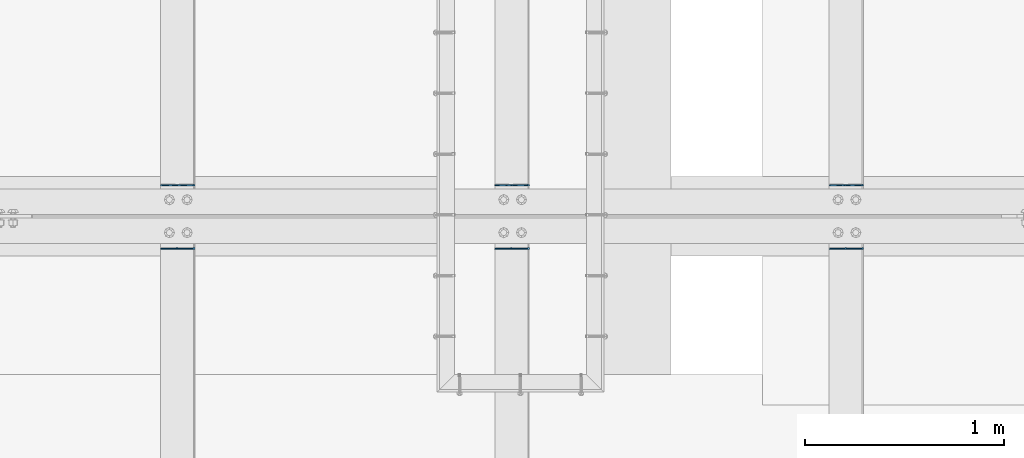
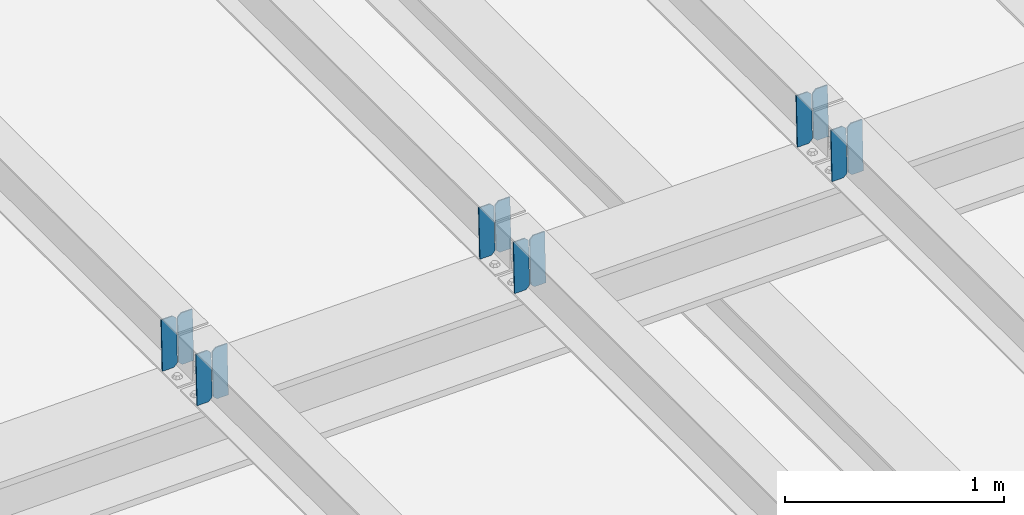
# One storey, part 3437 of 3843: 12 plates, 6 elements without a shape of their own.
"""IFC2X3 building model written with IfcOpenShell, lengths in millimetres."""

from ifc_helpers import new_model, si_unit, frame, origin_with_axes, place, context, subcontext, project, spatial, faceted_brep, material, type_object, element, aggregate, save


model = new_model("IFC2X3")

# Units and contexts
model_context = context("Model", 3, precision=1e-05, world=origin_with_axes())
body_context = subcontext(model_context, "Body", "Model", "MODEL_VIEW")
ifc_project = project(units=[si_unit("LENGTHUNIT", "METRE", prefix="MILLI"), si_unit("AREAUNIT", "SQUARE_METRE"), si_unit("VOLUMEUNIT", "CUBIC_METRE"), si_unit("MASSUNIT", "GRAM", prefix="KILO"), si_unit("TIMEUNIT", "SECOND"), si_unit("PLANEANGLEUNIT", "RADIAN"), si_unit("SOLIDANGLEUNIT", "STERADIAN"), si_unit("THERMODYNAMICTEMPERATUREUNIT", "DEGREE_CELSIUS"), si_unit("LUMINOUSINTENSITYUNIT", "LUMEN")], contexts=[model_context])

# Site, building, storey
site_placement = place(None, origin_with_axes())
site = spatial("IfcSite", under=ifc_project, at=site_placement, CompositionType="ELEMENT")
building_placement = place(site_placement, origin_with_axes())
building = spatial("IfcBuilding", under=site, at=building_placement, Name="Undefined", CompositionType="ELEMENT")
storey_placement = place(building_placement, origin_with_axes())
storey = spatial("IfcBuildingStorey", under=building, at=storey_placement, Name="Undefined", CompositionType="ELEMENT", Elevation=0.0)

# Assembly, plates
assembly_1_placement = place(storey_placement, origin_with_axes())
assembly_1 = element("IfcElementAssembly", 1, at=assembly_1_placement, inside=storey, Name="BEAM", AssemblyPlace="NOTDEFINED", PredefinedType="RIGID_FRAME")
ifc_material = material(Name="STEEL/A572-50")
plate_type = type_object("IfcPlateType", PredefinedType="NOTDEFINED")
plate_1_placement = place(assembly_1_placement, frame((61042.2966586121, 67426.9357460004, 46039.1469518312), z_axis=(-0.0211520975611275, 0.00180609999998706, 0.99977463799176), x_axis=(-0.999776269352655, -3.88860000349027e-05, -0.021152062007432)))
plate_1 = element("IfcPlate", 2, at=plate_1_placement, type_object=plate_type, material=ifc_material, Name="PLATE", context=body_context, shape_type="Brep", body=[
    faceted_brep([(0.0, -3.17499999999927, 0.0), (6.83940015733242e-10, -3.17499999996653, 288.924999998613), (6.54836185276508e-10, 3.17500000001746, 288.924999998591), (0.0, 3.17499999999927, 0.0), (60.3250007643655, -3.17500000017753, 288.924999998606), (60.3250007643219, 3.17499999979918, 288.924999998584), (79.3750000013097, -3.17500000025029, 269.875000761494), (79.375000001266, 3.17499999972642, 269.875000761487), (79.375000000713, -3.17500000026484, 19.0499992370605), (79.3750000006985, 3.17499999971187, 19.0499992370533), (60.325000763667, -3.17500000020664, -1.45519152283669e-11), (60.3250007636234, 3.17499999977736, -3.63797880709171e-11)], [[[0, 1, 2, 3]], [[1, 4, 5, 2]], [[4, 6, 7, 5]], [[6, 8, 9, 7]], [[8, 10, 11, 9]], [[10, 0, 3, 11]], [[5, 7, 9, 11, 3, 2]], [[10, 8, 6, 4, 1, 0]]]),
])
plate_2_placement = place(assembly_1_placement, frame((60956.5908379224, 67426.9324684449, 46037.3336911921), z_axis=(-0.0211520975611275, 0.00180609999998706, 0.99977463799176), x_axis=(-0.999776269352655, -3.88860000349027e-05, -0.021152062007432)))
plate_2 = element("IfcPlate", 3, at=plate_2_placement, type_object=plate_type, material=ifc_material, Name="PLATE", context=body_context, shape_type="Brep", body=[
    faceted_brep([(4.36557456851006e-11, -3.17499999998836, 19.0499992370969), (6.11180439591408e-10, -3.17499999996653, 269.875000761516), (5.96628524363041e-10, 3.17500000001746, 269.875000761502), (1.45519152283669e-11, 3.17499999998836, 19.0499992370824), (19.0499992376572, -3.17500000003201, 288.924999998606), (19.0499992376281, 3.1749999999447, 288.924999998584), (79.3750000013242, -3.17500000025029, 288.924999998591), (79.3750000013097, 3.1749999997337, 288.92499999857), (79.3750000006548, -3.17500000026484, -2.18278728425503e-11), (79.3750000006403, 3.17499999969732, -2.91038304567337e-11), (19.0499992370023, -3.17500000005384, 0.0), (19.0499992369587, 3.17499999992287, -1.45519152283669e-11)], [[[0, 1, 2, 3]], [[1, 4, 5, 2]], [[4, 6, 7, 5]], [[6, 8, 9, 7]], [[8, 10, 11, 9]], [[10, 0, 3, 11]], [[5, 7, 9, 11, 3, 2]], [[10, 8, 6, 4, 1, 0]]]),
])
aggregate(assembly_1, [plate_1, plate_2])

assembly_2_placement = place(storey_placement, origin_with_axes())
assembly_2 = element("IfcElementAssembly", 4, at=assembly_2_placement, inside=storey, Name="BEAM", AssemblyPlace="NOTDEFINED", PredefinedType="RIGID_FRAME")
plate_3_placement = place(assembly_2_placement, frame((61042.2966586102, 67109.8712665269, 46039.4833744107), z_axis=(-0.0211520982797228, 0.000347817999943799, 0.99977620883926), x_axis=(-0.999776269341478, -7.33700003415536e-06, -0.0211520970072466)))
plate_3 = element("IfcPlate", 5, at=plate_3_placement, type_object=plate_type, material=ifc_material, Name="PLATE", context=body_context, shape_type="Brep", body=[
    faceted_brep([(0.0, -3.17499999999927, 0.0), (6.83940015733242e-10, -3.17499999996653, 288.924999998613), (6.54836185276508e-10, 3.17500000001746, 288.924999998591), (0.0, 3.17499999999927, 0.0), (60.3250007643655, -3.17500000017753, 288.924999998606), (60.3250007643219, 3.17499999979918, 288.924999998584), (79.3750000013097, -3.17500000025029, 269.875000761494), (79.375000001266, 3.17499999972642, 269.875000761487), (79.375000000713, -3.17500000026484, 19.0499992370605), (79.3750000006985, 3.17499999971187, 19.0499992370533), (60.325000763667, -3.17500000020664, -1.45519152283669e-11), (60.3250007636234, 3.17499999977736, -3.63797880709171e-11)], [[[0, 1, 2, 3]], [[1, 4, 5, 2]], [[4, 6, 7, 5]], [[6, 8, 9, 7]], [[8, 10, 11, 9]], [[10, 0, 3, 11]], [[5, 7, 9, 11, 3, 2]], [[10, 8, 6, 4, 1, 0]]]),
])
plate_4_placement = place(assembly_2_placement, frame((60956.5908379209, 67109.8706375873, 46037.6701109189), z_axis=(-0.0211520982797228, 0.000347817999943799, 0.99977620883926), x_axis=(-0.999776269341478, -7.33700003415536e-06, -0.0211520970072466)))
plate_4 = element("IfcPlate", 6, at=plate_4_placement, type_object=plate_type, material=ifc_material, Name="PLATE", context=body_context, shape_type="Brep", body=[
    faceted_brep([(4.36557456851006e-11, -3.17499999998836, 19.0499992370969), (6.11180439591408e-10, -3.17499999996653, 269.875000761516), (5.96628524363041e-10, 3.17500000001746, 269.875000761502), (1.45519152283669e-11, 3.17499999998836, 19.0499992370824), (19.0499992376572, -3.17500000003201, 288.924999998606), (19.0499992376281, 3.1749999999447, 288.924999998584), (79.3750000013242, -3.17500000025029, 288.924999998591), (79.3750000013097, 3.1749999997337, 288.92499999857), (79.3750000006548, -3.17500000026484, -2.18278728425503e-11), (79.3750000006403, 3.17499999969732, -2.91038304567337e-11), (19.0499992370023, -3.17500000005384, 0.0), (19.0499992369587, 3.17499999992287, -1.45519152283669e-11)], [[[0, 1, 2, 3]], [[1, 4, 5, 2]], [[4, 6, 7, 5]], [[6, 8, 9, 7]], [[8, 10, 11, 9]], [[10, 0, 3, 11]], [[5, 7, 9, 11, 3, 2]], [[10, 8, 6, 4, 1, 0]]]),
])
aggregate(assembly_2, [plate_3, plate_4])

assembly_3_placement = place(storey_placement, origin_with_axes())
assembly_3 = element("IfcElementAssembly", 7, at=assembly_3_placement, inside=storey, Name="BEAM", AssemblyPlace="NOTDEFINED", PredefinedType="RIGID_FRAME")
plate_5_placement = place(assembly_3_placement, frame((59365.8966629378, 67426.9594819012, 46000.9743184199), z_axis=(-0.0211520975429012, 0.00172666700057744, 0.999774778332903), x_axis=(-0.99977626935114, -3.66870000375661e-05, -0.0211520660073899)))
plate_5 = element("IfcPlate", 8, at=plate_5_placement, type_object=plate_type, material=ifc_material, Name="PLATE", context=body_context, shape_type="Brep", body=[
    faceted_brep([(0.0, -3.17499999999927, 0.0), (6.83940015733242e-10, -3.17499999996653, 288.924999998613), (6.54836185276508e-10, 3.17500000001746, 288.924999998591), (0.0, 3.17499999999927, 0.0), (60.3250007643655, -3.17500000017753, 288.924999998606), (60.3250007643219, 3.17499999979918, 288.924999998584), (79.3750000013097, -3.17500000025029, 269.875000761494), (79.375000001266, 3.17499999972642, 269.875000761487), (79.375000000713, -3.17500000026484, 19.0499992370605), (79.3750000006985, 3.17499999971187, 19.0499992370533), (60.325000763667, -3.17500000020664, -1.45519152283669e-11), (60.3250007636234, 3.17499999977736, -3.63797880709171e-11)], [[[0, 1, 2, 3]], [[1, 4, 5, 2]], [[4, 6, 7, 5]], [[6, 8, 9, 7]], [[8, 10, 11, 9]], [[10, 0, 3, 11]], [[5, 7, 9, 11, 3, 2]], [[10, 8, 6, 4, 1, 0]]]),
])
plate_6_placement = place(assembly_3_placement, frame((59280.1908422482, 67426.956350813, 45999.1610575213), z_axis=(-0.0211520975429012, 0.00172666700057744, 0.999774778332903), x_axis=(-0.99977626935114, -3.66870000375661e-05, -0.0211520660073899)))
plate_6 = element("IfcPlate", 9, at=plate_6_placement, type_object=plate_type, material=ifc_material, Name="PLATE", context=body_context, shape_type="Brep", body=[
    faceted_brep([(4.36557456851006e-11, -3.17499999998836, 19.0499992370969), (6.11180439591408e-10, -3.17499999996653, 269.875000761516), (5.96628524363041e-10, 3.17500000001746, 269.875000761502), (1.45519152283669e-11, 3.17499999998836, 19.0499992370824), (19.0499992376572, -3.17500000003201, 288.924999998606), (19.0499992376281, 3.1749999999447, 288.924999998584), (79.3750000013242, -3.17500000025029, 288.924999998591), (79.3750000013097, 3.1749999997337, 288.92499999857), (79.3750000006548, -3.17500000026484, -2.18278728425503e-11), (79.3750000006403, 3.17499999969732, -2.91038304567337e-11), (19.0499992370023, -3.17500000005384, 0.0), (19.0499992369587, 3.17499999992287, -1.45519152283669e-11)], [[[0, 1, 2, 3]], [[1, 4, 5, 2]], [[4, 6, 7, 5]], [[6, 8, 9, 7]], [[8, 10, 11, 9]], [[10, 0, 3, 11]], [[5, 7, 9, 11, 3, 2]], [[10, 8, 6, 4, 1, 0]]]),
])
aggregate(assembly_3, [plate_5, plate_6])

assembly_4_placement = place(storey_placement, origin_with_axes())
assembly_4 = element("IfcElementAssembly", 10, at=assembly_4_placement, inside=storey, Name="BEAM", AssemblyPlace="NOTDEFINED", PredefinedType="RIGID_FRAME")
plate_7_placement = place(assembly_4_placement, frame((59365.8966586033, 67109.8737736412, 46001.2970998451), z_axis=(-0.021152098218743, 0.00033940999990591, 0.999776211730304), x_axis=(-0.999776269348334, -6.33400000515396e-06, -0.0211520970073616)))
plate_7 = element("IfcPlate", 11, at=plate_7_placement, type_object=plate_type, material=ifc_material, Name="PLATE", context=body_context, shape_type="Brep", body=[
    faceted_brep([(0.0, -3.17499999999927, 0.0), (6.83940015733242e-10, -3.17499999996653, 288.924999998613), (6.54836185276508e-10, 3.17500000001746, 288.924999998591), (0.0, 3.17499999999927, 0.0), (60.3250007643655, -3.17500000017753, 288.924999998606), (60.3250007643219, 3.17499999979918, 288.924999998584), (79.3750000013097, -3.17500000025029, 269.875000761494), (79.375000001266, 3.17499999972642, 269.875000761487), (79.375000000713, -3.17500000026484, 19.0499992370605), (79.3750000006985, 3.17499999971187, 19.0499992370533), (60.325000763667, -3.17500000020664, -1.45519152283669e-11), (60.3250007636234, 3.17499999977736, -3.63797880709171e-11)], [[[0, 1, 2, 3]], [[1, 4, 5, 2]], [[4, 6, 7, 5]], [[6, 8, 9, 7]], [[8, 10, 11, 9]], [[10, 0, 3, 11]], [[5, 7, 9, 11, 3, 2]], [[10, 8, 6, 4, 1, 0]]]),
])
plate_8_placement = place(assembly_4_placement, frame((59280.1908379128, 67109.8731599496, 45999.4838363487), z_axis=(-0.021152098218743, 0.00033940999990591, 0.999776211730304), x_axis=(-0.999776269348334, -6.33400000515396e-06, -0.0211520970073616)))
plate_8 = element("IfcPlate", 12, at=plate_8_placement, type_object=plate_type, material=ifc_material, Name="PLATE", context=body_context, shape_type="Brep", body=[
    faceted_brep([(4.36557456851006e-11, -3.17499999998836, 19.0499992370969), (6.11180439591408e-10, -3.17499999996653, 269.875000761516), (5.96628524363041e-10, 3.17500000001746, 269.875000761502), (1.45519152283669e-11, 3.17499999998836, 19.0499992370824), (19.0499992376572, -3.17500000003201, 288.924999998606), (19.0499992376281, 3.1749999999447, 288.924999998584), (79.3750000013242, -3.17500000025029, 288.924999998591), (79.3750000013097, 3.1749999997337, 288.92499999857), (79.3750000006548, -3.17500000026484, -2.18278728425503e-11), (79.3750000006403, 3.17499999969732, -2.91038304567337e-11), (19.0499992370023, -3.17500000005384, 0.0), (19.0499992369587, 3.17499999992287, -1.45519152283669e-11)], [[[0, 1, 2, 3]], [[1, 4, 5, 2]], [[4, 6, 7, 5]], [[6, 8, 9, 7]], [[8, 10, 11, 9]], [[10, 0, 3, 11]], [[5, 7, 9, 11, 3, 2]], [[10, 8, 6, 4, 1, 0]]]),
])
aggregate(assembly_4, [plate_7, plate_8])

assembly_5_placement = place(storey_placement, origin_with_axes())
assembly_5 = element("IfcElementAssembly", 13, at=assembly_5_placement, inside=storey, Name="BEAM", AssemblyPlace="NOTDEFINED", PredefinedType="RIGID_FRAME")
plate_9_placement = place(assembly_5_placement, frame((57689.4964826803, 67426.9856471175, 45962.2269495095), z_axis=(-0.0211520983879091, 0.0016390989995416, 0.999774925714912), x_axis=(-0.999776269344824, -3.44869999710776e-05, -0.0211520700072795)))
plate_9 = element("IfcPlate", 14, at=plate_9_placement, type_object=plate_type, material=ifc_material, Name="PLATE", context=body_context, shape_type="Brep", body=[
    faceted_brep([(0.0, -3.17499999999927, 0.0), (6.83940015733242e-10, -3.17499999996653, 288.924999998613), (6.54836185276508e-10, 3.17500000001746, 288.924999998591), (0.0, 3.17499999999927, 0.0), (60.3250007643655, -3.17500000017753, 288.924999998606), (60.3250007643219, 3.17499999979918, 288.924999998584), (79.3750000013097, -3.17500000025029, 269.875000761494), (79.375000001266, 3.17499999972642, 269.875000761487), (79.375000000713, -3.17500000026484, 19.0499992370605), (79.3750000006985, 3.17499999971187, 19.0499992370533), (60.325000763667, -3.17500000020664, -1.45519152283669e-11), (60.3250007636234, 3.17499999977736, -3.63797880709171e-11)], [[[0, 1, 2, 3]], [[1, 4, 5, 2]], [[4, 6, 7, 5]], [[6, 8, 9, 7]], [[8, 10, 11, 9]], [[10, 0, 3, 11]], [[5, 7, 9, 11, 3, 2]], [[10, 8, 6, 4, 1, 0]]]),
])
plate_10_placement = place(assembly_5_placement, frame((57603.7906619906, 67426.9826767349, 45960.4136883423), z_axis=(-0.0211520983879091, 0.0016390989995416, 0.999774925714912), x_axis=(-0.999776269344824, -3.44869999710776e-05, -0.0211520700072795)))
plate_10 = element("IfcPlate", 15, at=plate_10_placement, type_object=plate_type, material=ifc_material, Name="PLATE", context=body_context, shape_type="Brep", body=[
    faceted_brep([(4.36557456851006e-11, -3.17499999998836, 19.0499992370969), (6.11180439591408e-10, -3.17499999996653, 269.875000761516), (5.96628524363041e-10, 3.17500000001746, 269.875000761502), (1.45519152283669e-11, 3.17499999998836, 19.0499992370824), (19.0499992376572, -3.17500000003201, 288.924999998606), (19.0499992376281, 3.1749999999447, 288.924999998584), (79.3750000013242, -3.17500000025029, 288.924999998591), (79.3750000013097, 3.1749999997337, 288.92499999857), (79.3750000006548, -3.17500000026484, -2.18278728425503e-11), (79.3750000006403, 3.17499999969732, -2.91038304567337e-11), (19.0499992370023, -3.17500000005384, 0.0), (19.0499992369587, 3.17499999992287, -1.45519152283669e-11)], [[[0, 1, 2, 3]], [[1, 4, 5, 2]], [[4, 6, 7, 5]], [[6, 8, 9, 7]], [[8, 10, 11, 9]], [[10, 0, 3, 11]], [[5, 7, 9, 11, 3, 2]], [[10, 8, 6, 4, 1, 0]]]),
])
aggregate(assembly_5, [plate_9, plate_10])

assembly_6_placement = place(storey_placement, origin_with_axes())
assembly_6 = element("IfcElementAssembly", 16, at=assembly_6_placement, inside=storey, Name="BEAM", AssemblyPlace="NOTDEFINED", PredefinedType="RIGID_FRAME")
plate_11_placement = place(assembly_6_placement, frame((57689.496481677, 67109.8829565647, 45962.531201538), z_axis=(-0.0211520980146961, 0.000308619999916118, 0.999776221713275), x_axis=(-0.999776269348334, -6.33400000515396e-06, -0.0211520970073616)))
plate_11 = element("IfcPlate", 17, at=plate_11_placement, type_object=plate_type, material=ifc_material, Name="PLATE", context=body_context, shape_type="Brep", body=[
    faceted_brep([(0.0, -3.17499999999927, 0.0), (6.83940015733242e-10, -3.17499999996653, 288.924999998613), (6.54836185276508e-10, 3.17500000001746, 288.924999998591), (0.0, 3.17499999999927, 0.0), (60.3250007643655, -3.17500000017753, 288.924999998606), (60.3250007643219, 3.17499999979918, 288.924999998584), (79.3750000013097, -3.17500000025029, 269.875000761494), (79.375000001266, 3.17499999972642, 269.875000761487), (79.375000000713, -3.17500000026484, 19.0499992370605), (79.3750000006985, 3.17499999971187, 19.0499992370533), (60.325000763667, -3.17500000020664, -1.45519152283669e-11), (60.3250007636234, 3.17499999977736, -3.63797880709171e-11)], [[[0, 1, 2, 3]], [[1, 4, 5, 2]], [[4, 6, 7, 5]], [[6, 8, 9, 7]], [[8, 10, 11, 9]], [[10, 0, 3, 11]], [[5, 7, 9, 11, 3, 2]], [[10, 8, 6, 4, 1, 0]]]),
])
plate_12_placement = place(assembly_6_placement, frame((57603.7906609877, 67109.8823969166, 45960.717938023), z_axis=(-0.0211520980146961, 0.000308619999916118, 0.999776221713275), x_axis=(-0.999776269348334, -6.33400000515396e-06, -0.0211520970073616)))
plate_12 = element("IfcPlate", 18, at=plate_12_placement, type_object=plate_type, material=ifc_material, Name="PLATE", context=body_context, shape_type="Brep", body=[
    faceted_brep([(4.36557456851006e-11, -3.17499999998836, 19.0499992370969), (6.11180439591408e-10, -3.17499999996653, 269.875000761516), (5.96628524363041e-10, 3.17500000001746, 269.875000761502), (1.45519152283669e-11, 3.17499999998836, 19.0499992370824), (19.0499992376572, -3.17500000003201, 288.924999998606), (19.0499992376281, 3.1749999999447, 288.924999998584), (79.3750000013242, -3.17500000025029, 288.924999998591), (79.3750000013097, 3.1749999997337, 288.92499999857), (79.3750000006548, -3.17500000026484, -2.18278728425503e-11), (79.3750000006403, 3.17499999969732, -2.91038304567337e-11), (19.0499992370023, -3.17500000005384, 0.0), (19.0499992369587, 3.17499999992287, -1.45519152283669e-11)], [[[0, 1, 2, 3]], [[1, 4, 5, 2]], [[4, 6, 7, 5]], [[6, 8, 9, 7]], [[8, 10, 11, 9]], [[10, 0, 3, 11]], [[5, 7, 9, 11, 3, 2]], [[10, 8, 6, 4, 1, 0]]]),
])
aggregate(assembly_6, [plate_11, plate_12])

save(model, "model.ifc")
